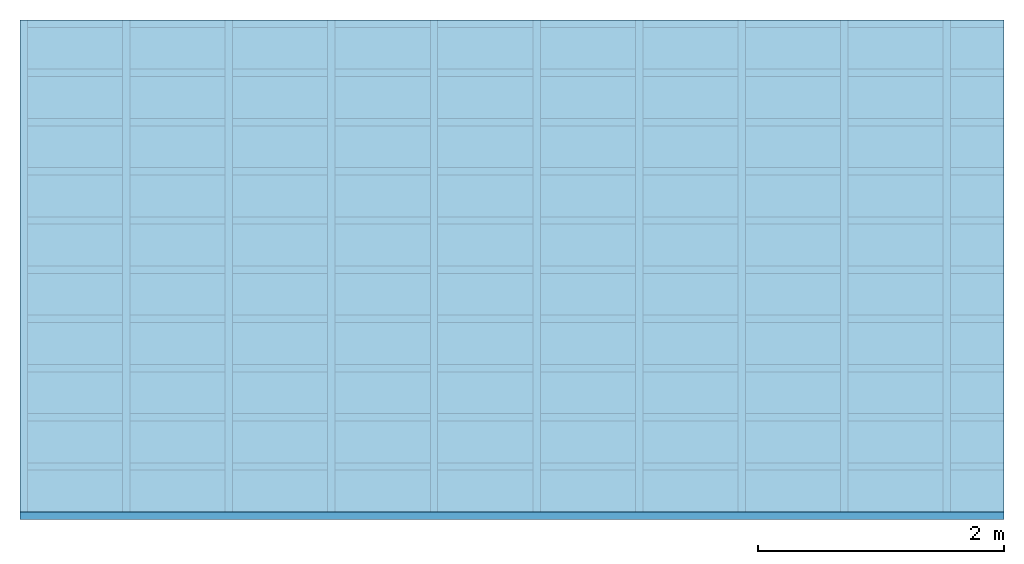
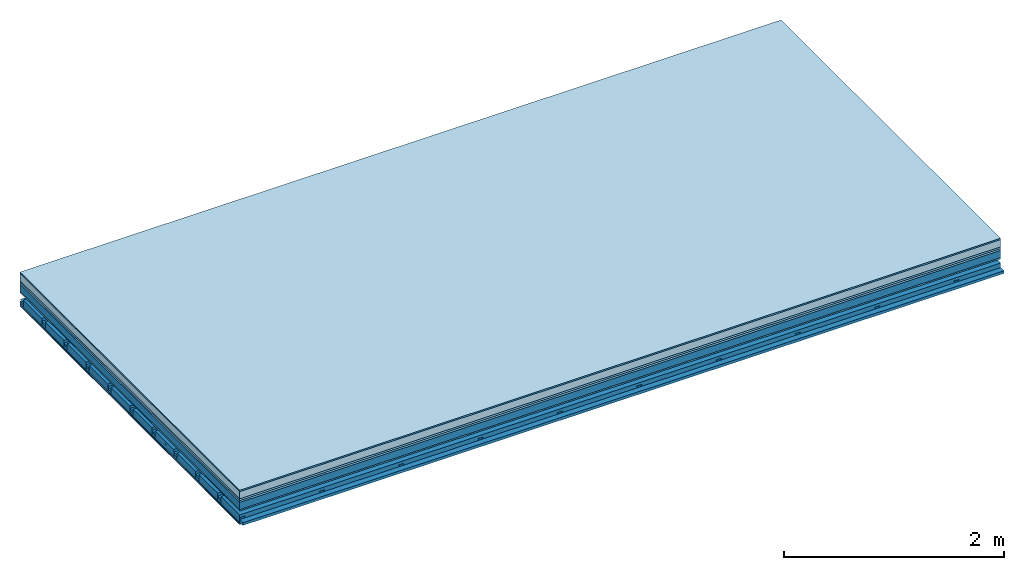
# One storey: 8 plates, 4 members, 1 element without a shape of its own.
"""IFC4 building model written with IfcOpenShell, lengths in metres."""

from ifc_helpers import new_model, si_unit, derived_unit, direction, frame, frame_2d, origin, origin_with_axes, place, context, project, spatial, polyline, rectangle, outline, extrude, material, layer, layer_set, type_object, element, aggregate, save


model = new_model("IFC4")

# Units and contexts
plan_context = context("Plan", 3, precision=1e-05, world=origin(), true_north=direction((0.0, 1.0)))
model_context = context("Model", 3, precision=1e-05, world=origin(), true_north=direction((0.0, 1.0)))
ifc_project = project(units=[si_unit("LENGTHUNIT", "METRE"), derived_unit("SOUNDPRESSUREUNIT", [(si_unit("PRESSUREUNIT", "PASCAL", prefix="MICRO"), 0)]), si_unit("ENERGYUNIT", "JOULE", prefix="MEGA"), si_unit("MASSUNIT", "GRAM", prefix="KILO"), derived_unit("THERMALTRANSMITTANCEUNIT", [(si_unit("POWERUNIT", "WATT"), 1), (si_unit("AREAUNIT", "SQUARE_METRE"), -1), (si_unit("THERMODYNAMICTEMPERATUREUNIT", "KELVIN"), -1)]), derived_unit("AREADENSITYUNIT", [(si_unit("MASSUNIT", "GRAM", prefix="KILO"), 1), (si_unit("AREAUNIT", "SQUARE_METRE"), -1)]), derived_unit("USERDEFINED", [(si_unit("ENERGYUNIT", "JOULE", prefix="MEGA"), 1), (si_unit("AREAUNIT", "SQUARE_METRE"), -1)])], contexts=[plan_context, model_context])

# Site, building, storey
site = spatial("IfcSite", under=ifc_project)
building_placement = place(None, origin())
building = spatial("IfcBuilding", under=site, at=building_placement)
storey_placement = place(building_placement, origin())
storey = spatial("IfcBuildingStorey", under=building, at=storey_placement)

# Slab, members, plates
ifc_material_1 = material(Category="11.013")
ifc_layer_1 = layer(ifc_material_1, 0.015, Name="Flooring")
ifc_material_2 = material(Name="Cement screed", Category="04.006")
ifc_layer_2 = layer(ifc_material_2, 0.08, Name="On-material")
ifc_material_3 = material(Name="Wood fiber generic product", Category="10.009")
ifc_layer_3 = layer(ifc_material_3, 0.02, Name="Impact sound insulation")
ifc_material_4 = material(Category="10.004")
ifc_layer_4 = layer(ifc_material_4, 0.02, Name="Additional insulation")
ifc_material_5 = material(Name="no composite action")
ifc_layer_5 = layer(ifc_material_5, 0.0, Name="Bond")
ifc_layer_6 = layer(None, 0.08, Name="Supporting structure")
ifc_material_6 = material(Name="of the art")
ifc_layer_7 = layer(ifc_material_6, 0.0, Name="Bond")
ifc_material_7 = material(Category="03.007")
ifc_layer_8 = layer(ifc_material_7, 0.015, Name="Lower layer 1")
ifc_layer_9 = layer(None, 0.095, Name="Coupling")
ifc_layer_10 = layer(None, 0.03, Name="Battens / profiles")
ifc_material_8 = material(Name="Plasterboard type A", Category="03.008")
ifc_layer_11 = layer(ifc_material_8, 0.0125, Name="Ceiling covering 1st layer")
ifc_layer_12 = layer(ifc_material_8, 0.0125, Name="Ceiling covering layer 2")
ifc_material_9 = material(Category="04.001")
ifc_layer_13 = layer(ifc_material_9, 0.003, Name="Surface / treatment")
ifc_layer_set = layer_set([ifc_layer_1, ifc_layer_2, ifc_layer_3, ifc_layer_4, ifc_layer_5, ifc_layer_6, ifc_layer_7, ifc_layer_8, ifc_layer_9, ifc_layer_10, ifc_layer_11, ifc_layer_12, ifc_layer_13])
slab_type = type_object("IfcSlabType", Name="A2157", PredefinedType="NOTDEFINED", material=ifc_layer_set)
slab_placement = place(None, frame((0.0, 0.0, 0.0), z_axis=(0.0, 0.0, -1.0), x_axis=(1.0, 0.0, 0.0)))
slab = element("IfcSlab", 1, at=slab_placement, inside=storey, type_object=slab_type, material=ifc_layer_set, Name="Slab #1")
ifc_material_10 = material(Name="Solid timber panel")
member_1_placement = place(slab_placement, origin())
member_1 = element("IfcMember", 2, at=member_1_placement, material=ifc_material_10, Name="Supporting structure", context=plan_context, shape_type="SweptSolid", body=[
    extrude(rectangle(XDim=1.0, YDim=0.08, at=frame_2d((0.5, 0.04), x_axis=(1.0, 0.0))), frame((0.0, 4.0, 0.135), z_axis=(0.0, -1.0, 0.0), x_axis=(1.0, 0.0, 0.0)), (0.0, 0.0, 1.0), 4.0),
    extrude(rectangle(XDim=1.0, YDim=0.08, at=frame_2d((0.5, 0.04), x_axis=(1.0, 0.0))), frame((1.0, 4.0, 0.135), z_axis=(0.0, -1.0, 0.0), x_axis=(1.0, 0.0, 0.0)), (0.0, 0.0, 1.0), 4.0),
    extrude(rectangle(XDim=1.0, YDim=0.08, at=frame_2d((0.5, 0.04), x_axis=(1.0, 0.0))), frame((2.0, 4.0, 0.135), z_axis=(0.0, -1.0, 0.0), x_axis=(1.0, 0.0, 0.0)), (0.0, 0.0, 1.0), 4.0),
    extrude(rectangle(XDim=1.0, YDim=0.08, at=frame_2d((0.5, 0.04), x_axis=(1.0, 0.0))), frame((3.0, 4.0, 0.135), z_axis=(0.0, -1.0, 0.0), x_axis=(1.0, 0.0, 0.0)), (0.0, 0.0, 1.0), 4.0),
    extrude(rectangle(XDim=1.0, YDim=0.08, at=frame_2d((0.5, 0.04), x_axis=(1.0, 0.0))), frame((4.0, 4.0, 0.135), z_axis=(0.0, -1.0, 0.0), x_axis=(1.0, 0.0, 0.0)), (0.0, 0.0, 1.0), 4.0),
    extrude(rectangle(XDim=1.0, YDim=0.08, at=frame_2d((0.5, 0.04), x_axis=(1.0, 0.0))), frame((5.0, 4.0, 0.135), z_axis=(0.0, -1.0, 0.0), x_axis=(1.0, 0.0, 0.0)), (0.0, 0.0, 1.0), 4.0),
    extrude(rectangle(XDim=1.0, YDim=0.08, at=frame_2d((0.5, 0.04), x_axis=(1.0, 0.0))), frame((6.0, 4.0, 0.135), z_axis=(0.0, -1.0, 0.0), x_axis=(1.0, 0.0, 0.0)), (0.0, 0.0, 1.0), 4.0),
    extrude(rectangle(XDim=1.0, YDim=0.08, at=frame_2d((0.5, 0.04), x_axis=(1.0, 0.0))), frame((7.0, 4.0, 0.135), z_axis=(0.0, -1.0, 0.0), x_axis=(1.0, 0.0, 0.0)), (0.0, 0.0, 1.0), 4.0),
])
ifc_material_11 = material()
member_2_placement = place(slab_placement, origin())
member_2 = element("IfcMember", 3, at=member_2_placement, material=ifc_material_11, Name="Coupling", context=plan_context, shape_type="SweptSolid", body=[
    extrude(outline(polyline([(0.0, 0.0), (0.06, 0.0), (0.04, 0.02), (0.02, 0.02), (0.0, 0.0)])), frame((0.0, 4.0, 0.305), z_axis=(0.0, -1.0, 0.0), x_axis=(1.0, 0.0, 0.0)), (0.0, 0.0, 1.0), 4.0),
    extrude(outline(polyline([(0.0, 0.0), (0.06, 0.0), (0.04, 0.02), (0.02, 0.02), (0.0, 0.0)])), frame((0.834, 4.0, 0.305), z_axis=(0.0, -1.0, 0.0), x_axis=(1.0, 0.0, 0.0)), (0.0, 0.0, 1.0), 4.0),
    extrude(outline(polyline([(0.0, 0.0), (0.06, 0.0), (0.04, 0.02), (0.02, 0.02), (0.0, 0.0)])), frame((1.668, 4.0, 0.305), z_axis=(0.0, -1.0, 0.0), x_axis=(1.0, 0.0, 0.0)), (0.0, 0.0, 1.0), 4.0),
    extrude(outline(polyline([(0.0, 0.0), (0.06, 0.0), (0.04, 0.02), (0.02, 0.02), (0.0, 0.0)])), frame((2.502, 4.0, 0.305), z_axis=(0.0, -1.0, 0.0), x_axis=(1.0, 0.0, 0.0)), (0.0, 0.0, 1.0), 4.0),
    extrude(outline(polyline([(0.0, 0.0), (0.06, 0.0), (0.04, 0.02), (0.02, 0.02), (0.0, 0.0)])), frame((3.336, 4.0, 0.305), z_axis=(0.0, -1.0, 0.0), x_axis=(1.0, 0.0, 0.0)), (0.0, 0.0, 1.0), 4.0),
    extrude(outline(polyline([(0.0, 0.0), (0.06, 0.0), (0.04, 0.02), (0.02, 0.02), (0.0, 0.0)])), frame((4.17, 4.0, 0.305), z_axis=(0.0, -1.0, 0.0), x_axis=(1.0, 0.0, 0.0)), (0.0, 0.0, 1.0), 4.0),
    extrude(outline(polyline([(0.0, 0.0), (0.06, 0.0), (0.04, 0.02), (0.02, 0.02), (0.0, 0.0)])), frame((5.004, 4.0, 0.305), z_axis=(0.0, -1.0, 0.0), x_axis=(1.0, 0.0, 0.0)), (0.0, 0.0, 1.0), 4.0),
    extrude(outline(polyline([(0.0, 0.0), (0.06, 0.0), (0.04, 0.02), (0.02, 0.02), (0.0, 0.0)])), frame((5.838, 4.0, 0.305), z_axis=(0.0, -1.0, 0.0), x_axis=(1.0, 0.0, 0.0)), (0.0, 0.0, 1.0), 4.0),
    extrude(outline(polyline([(0.0, 0.0), (0.06, 0.0), (0.04, 0.02), (0.02, 0.02), (0.0, 0.0)])), frame((6.672, 4.0, 0.305), z_axis=(0.0, -1.0, 0.0), x_axis=(1.0, 0.0, 0.0)), (0.0, 0.0, 1.0), 4.0),
    extrude(outline(polyline([(0.0, 0.0), (0.06, 0.0), (0.04, 0.02), (0.02, 0.02), (0.0, 0.0)])), frame((7.506, 4.0, 0.305), z_axis=(0.0, -1.0, 0.0), x_axis=(1.0, 0.0, 0.0)), (0.0, 0.0, 1.0), 4.0),
])
member_3_placement = place(slab_placement, origin())
member_3 = element("IfcMember", 4, at=member_3_placement, material=ifc_material_11, Name="Battens / profiles", context=plan_context, shape_type="SweptSolid", body=[
    extrude(rectangle(XDim=0.06, YDim=0.03, at=frame_2d((0.03, 0.015), x_axis=(1.0, 0.0))), frame((0.0, 0.0, 0.325), z_axis=(1.0, 0.0, 0.0), x_axis=(0.0, 1.0, 0.0)), (0.0, 0.0, 1.0), 8.0),
    extrude(rectangle(XDim=0.06, YDim=0.03, at=frame_2d((0.03, 0.015), x_axis=(1.0, 0.0))), frame((0.0, 0.4, 0.325), z_axis=(1.0, 0.0, 0.0), x_axis=(0.0, 1.0, 0.0)), (0.0, 0.0, 1.0), 8.0),
    extrude(rectangle(XDim=0.06, YDim=0.03, at=frame_2d((0.03, 0.015), x_axis=(1.0, 0.0))), frame((0.0, 0.8, 0.325), z_axis=(1.0, 0.0, 0.0), x_axis=(0.0, 1.0, 0.0)), (0.0, 0.0, 1.0), 8.0),
    extrude(rectangle(XDim=0.06, YDim=0.03, at=frame_2d((0.03, 0.015), x_axis=(1.0, 0.0))), frame((0.0, 1.2, 0.325), z_axis=(1.0, 0.0, 0.0), x_axis=(0.0, 1.0, 0.0)), (0.0, 0.0, 1.0), 8.0),
    extrude(rectangle(XDim=0.06, YDim=0.03, at=frame_2d((0.03, 0.015), x_axis=(1.0, 0.0))), frame((0.0, 1.6, 0.325), z_axis=(1.0, 0.0, 0.0), x_axis=(0.0, 1.0, 0.0)), (0.0, 0.0, 1.0), 8.0),
    extrude(rectangle(XDim=0.06, YDim=0.03, at=frame_2d((0.03, 0.015), x_axis=(1.0, 0.0))), frame((0.0, 2.0, 0.325), z_axis=(1.0, 0.0, 0.0), x_axis=(0.0, 1.0, 0.0)), (0.0, 0.0, 1.0), 8.0),
    extrude(rectangle(XDim=0.06, YDim=0.03, at=frame_2d((0.03, 0.015), x_axis=(1.0, 0.0))), frame((0.0, 2.4, 0.325), z_axis=(1.0, 0.0, 0.0), x_axis=(0.0, 1.0, 0.0)), (0.0, 0.0, 1.0), 8.0),
    extrude(rectangle(XDim=0.06, YDim=0.03, at=frame_2d((0.03, 0.015), x_axis=(1.0, 0.0))), frame((0.0, 2.8, 0.325), z_axis=(1.0, 0.0, 0.0), x_axis=(0.0, 1.0, 0.0)), (0.0, 0.0, 1.0), 8.0),
    extrude(rectangle(XDim=0.06, YDim=0.03, at=frame_2d((0.03, 0.015), x_axis=(1.0, 0.0))), frame((0.0, 3.2, 0.325), z_axis=(1.0, 0.0, 0.0), x_axis=(0.0, 1.0, 0.0)), (0.0, 0.0, 1.0), 8.0),
    extrude(rectangle(XDim=0.06, YDim=0.03, at=frame_2d((0.03, 0.015), x_axis=(1.0, 0.0))), frame((0.0, 3.6, 0.325), z_axis=(1.0, 0.0, 0.0), x_axis=(0.0, 1.0, 0.0)), (0.0, 0.0, 1.0), 8.0),
    extrude(rectangle(XDim=0.06, YDim=0.03, at=frame_2d((0.03, 0.015), x_axis=(1.0, 0.0))), frame((0.0, 4.0, 0.325), z_axis=(1.0, 0.0, 0.0), x_axis=(0.0, 1.0, 0.0)), (0.0, 0.0, 1.0), 8.0),
])
ifc_material_12 = material()
member_4_placement = place(slab_placement, origin())
member_4 = element("IfcMember", 5, at=member_4_placement, material=ifc_material_12, Name="Cavity", context=plan_context, shape_type="SweptSolid", body=[
    extrude(rectangle(XDim=0.34, YDim=0.08, at=frame_2d((0.17, 0.04), x_axis=(1.0, 0.0))), frame((0.0, 0.06, 0.275), z_axis=(1.0, 0.0, 0.0), x_axis=(0.0, 1.0, 0.0)), (0.0, 0.0, 1.0), 8.0),
    extrude(rectangle(XDim=0.34, YDim=0.08, at=frame_2d((0.17, 0.04), x_axis=(1.0, 0.0))), frame((0.0, 0.46, 0.275), z_axis=(1.0, 0.0, 0.0), x_axis=(0.0, 1.0, 0.0)), (0.0, 0.0, 1.0), 8.0),
    extrude(rectangle(XDim=0.34, YDim=0.08, at=frame_2d((0.17, 0.04), x_axis=(1.0, 0.0))), frame((0.0, 0.86, 0.275), z_axis=(1.0, 0.0, 0.0), x_axis=(0.0, 1.0, 0.0)), (0.0, 0.0, 1.0), 8.0),
    extrude(rectangle(XDim=0.34, YDim=0.08, at=frame_2d((0.17, 0.04), x_axis=(1.0, 0.0))), frame((0.0, 1.26, 0.275), z_axis=(1.0, 0.0, 0.0), x_axis=(0.0, 1.0, 0.0)), (0.0, 0.0, 1.0), 8.0),
    extrude(rectangle(XDim=0.34, YDim=0.08, at=frame_2d((0.17, 0.04), x_axis=(1.0, 0.0))), frame((0.0, 1.66, 0.275), z_axis=(1.0, 0.0, 0.0), x_axis=(0.0, 1.0, 0.0)), (0.0, 0.0, 1.0), 8.0),
    extrude(rectangle(XDim=0.34, YDim=0.08, at=frame_2d((0.17, 0.04), x_axis=(1.0, 0.0))), frame((0.0, 2.06, 0.275), z_axis=(1.0, 0.0, 0.0), x_axis=(0.0, 1.0, 0.0)), (0.0, 0.0, 1.0), 8.0),
    extrude(rectangle(XDim=0.34, YDim=0.08, at=frame_2d((0.17, 0.04), x_axis=(1.0, 0.0))), frame((0.0, 2.46, 0.275), z_axis=(1.0, 0.0, 0.0), x_axis=(0.0, 1.0, 0.0)), (0.0, 0.0, 1.0), 8.0),
    extrude(rectangle(XDim=0.34, YDim=0.08, at=frame_2d((0.17, 0.04), x_axis=(1.0, 0.0))), frame((0.0, 2.86, 0.275), z_axis=(1.0, 0.0, 0.0), x_axis=(0.0, 1.0, 0.0)), (0.0, 0.0, 1.0), 8.0),
    extrude(rectangle(XDim=0.34, YDim=0.08, at=frame_2d((0.17, 0.04), x_axis=(1.0, 0.0))), frame((0.0, 3.26, 0.275), z_axis=(1.0, 0.0, 0.0), x_axis=(0.0, 1.0, 0.0)), (0.0, 0.0, 1.0), 8.0),
    extrude(rectangle(XDim=0.34, YDim=0.08, at=frame_2d((0.17, 0.04), x_axis=(1.0, 0.0))), frame((0.0, 3.66, 0.275), z_axis=(1.0, 0.0, 0.0), x_axis=(0.0, 1.0, 0.0)), (0.0, 0.0, 1.0), 8.0),
])
plate_1_placement = place(slab_placement, origin())
plate_1 = element("IfcPlate", 6, at=plate_1_placement, material=ifc_material_1, Name="Flooring", context=plan_context, shape_type="SweptSolid", body=[
    extrude(rectangle(XDim=8.0, YDim=4.0, at=frame_2d((4.0, 2.0), x_axis=(1.0, 0.0))), origin_with_axes(), (0.0, 0.0, 1.0), 0.015),
])
plate_2_placement = place(slab_placement, origin())
plate_2 = element("IfcPlate", 7, at=plate_2_placement, material=ifc_material_2, Name="On-material", context=plan_context, shape_type="SweptSolid", body=[
    extrude(rectangle(XDim=8.0, YDim=4.0, at=frame_2d((4.0, 2.0), x_axis=(1.0, 0.0))), frame((0.0, 0.0, 0.015), z_axis=(0.0, 0.0, 1.0), x_axis=(1.0, 0.0, 0.0)), (0.0, 0.0, 1.0), 0.08),
])
plate_3_placement = place(slab_placement, origin())
plate_3 = element("IfcPlate", 8, at=plate_3_placement, material=ifc_material_3, Name="Impact sound insulation", context=plan_context, shape_type="SweptSolid", body=[
    extrude(rectangle(XDim=8.0, YDim=4.0, at=frame_2d((4.0, 2.0), x_axis=(1.0, 0.0))), frame((0.0, 0.0, 0.095), z_axis=(0.0, 0.0, 1.0), x_axis=(1.0, 0.0, 0.0)), (0.0, 0.0, 1.0), 0.02),
])
plate_4_placement = place(slab_placement, origin())
plate_4 = element("IfcPlate", 9, at=plate_4_placement, material=ifc_material_4, Name="Additional insulation", context=plan_context, shape_type="SweptSolid", body=[
    extrude(rectangle(XDim=8.0, YDim=4.0, at=frame_2d((4.0, 2.0), x_axis=(1.0, 0.0))), frame((0.0, 0.0, 0.115), z_axis=(0.0, 0.0, 1.0), x_axis=(1.0, 0.0, 0.0)), (0.0, 0.0, 1.0), 0.02),
])
plate_5_placement = place(slab_placement, origin())
plate_5 = element("IfcPlate", 10, at=plate_5_placement, material=ifc_material_7, Name="Lower layer 1", context=plan_context, shape_type="SweptSolid", body=[
    extrude(rectangle(XDim=8.0, YDim=4.0, at=frame_2d((4.0, 2.0), x_axis=(1.0, 0.0))), frame((0.0, 0.0, 0.215), z_axis=(0.0, 0.0, 1.0), x_axis=(1.0, 0.0, 0.0)), (0.0, 0.0, 1.0), 0.015),
])
plate_6_placement = place(slab_placement, origin())
plate_6 = element("IfcPlate", 11, at=plate_6_placement, material=ifc_material_8, Name="Ceiling covering 1st layer", context=plan_context, shape_type="SweptSolid", body=[
    extrude(rectangle(XDim=8.0, YDim=4.0, at=frame_2d((4.0, 2.0), x_axis=(1.0, 0.0))), frame((0.0, 0.0, 0.355), z_axis=(0.0, 0.0, 1.0), x_axis=(1.0, 0.0, 0.0)), (0.0, 0.0, 1.0), 0.0125),
])
plate_7_placement = place(slab_placement, origin())
plate_7 = element("IfcPlate", 12, at=plate_7_placement, material=ifc_material_8, Name="Ceiling covering layer 2", context=plan_context, shape_type="SweptSolid", body=[
    extrude(rectangle(XDim=8.0, YDim=4.0, at=frame_2d((4.0, 2.0), x_axis=(1.0, 0.0))), frame((0.0, 0.0, 0.3675), z_axis=(0.0, 0.0, 1.0), x_axis=(1.0, 0.0, 0.0)), (0.0, 0.0, 1.0), 0.0125),
])
plate_8_placement = place(slab_placement, origin())
plate_8 = element("IfcPlate", 13, at=plate_8_placement, material=ifc_material_9, Name="Surface / treatment", context=plan_context, shape_type="SweptSolid", body=[
    extrude(rectangle(XDim=8.0, YDim=4.0, at=frame_2d((4.0, 2.0), x_axis=(1.0, 0.0))), frame((0.0, 0.0, 0.38), z_axis=(0.0, 0.0, 1.0), x_axis=(1.0, 0.0, 0.0)), (0.0, 0.0, 1.0), 0.003),
])
aggregate(slab, [plate_1, plate_2, plate_3, plate_4, member_1, plate_5, member_2, member_3, member_4, plate_6, plate_7, plate_8])

save(model, "model.ifc")
